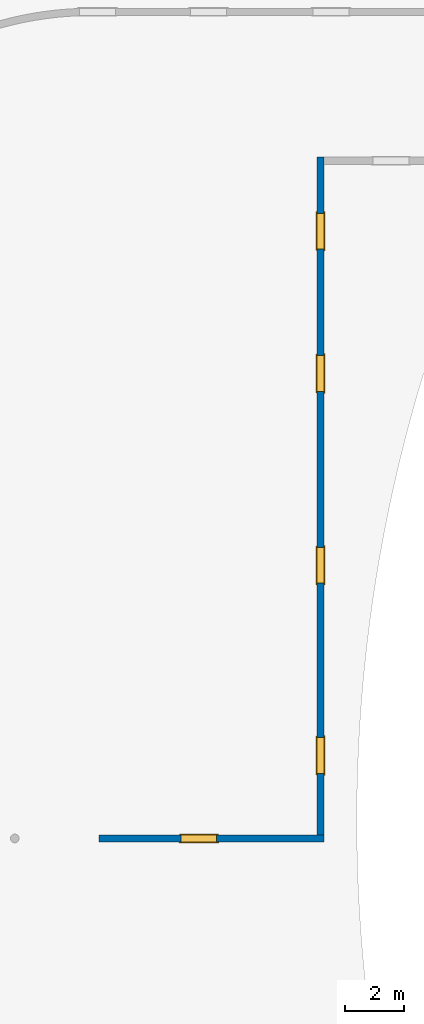
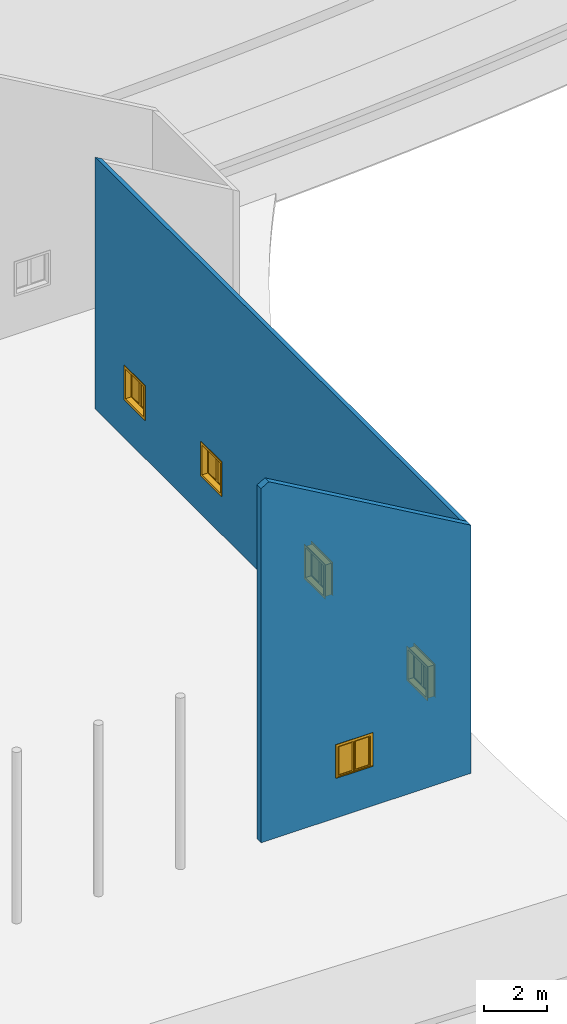
# One storey, part 8 of 39: 5 windows, 2 walls, 5 openings.
"""IFC2X3 building model written with IfcOpenShell, lengths in millimetres."""

from ifc_helpers import new_model, entity, si_unit, converted_unit, derived_unit, direction, frame, frame_2d, origin, origin_2d_with_axis, place, context, subcontext, project, spatial, polyline, rectangle, outline, extrude, clip, bounded_halfspace, source, transform, mapped, material, material_list, layer, layer_set, layer_usage, type_object, type_shapes, element, fill, save


model = new_model("IFC2X3")

# Units and contexts
model_context = context("Model", 3, precision=1e-06, world=origin(), true_north=direction((2.0, 6.12303176911189e-17, 1.0)))
context_of_model = context(None, 3, precision=1e-06, world=origin(), true_north=direction((2.0, 6.12303176911189e-17, 1.0)))
body_context = subcontext(model_context, "Body", "Model", "MODEL_VIEW")
ifc_project = project(units=[si_unit("LENGTHUNIT", "METRE", prefix="MILLI"), si_unit("AREAUNIT", "SQUARE_METRE", prefix="MILLI"), si_unit("VOLUMEUNIT", "CUBIC_METRE", prefix="MILLI"), converted_unit("PLANEANGLEUNIT", "DEGREE", entity("IfcRatioMeasure", 0.0174532925199433), si_unit("PLANEANGLEUNIT", "RADIAN"), dimensions=[0, 0, 0, 0, 0, 0, 0]), si_unit("MASSUNIT", "GRAM", prefix="KILO"), si_unit("TIMEUNIT", "SECOND"), si_unit("THERMODYNAMICTEMPERATUREUNIT", "KELVIN"), derived_unit("THERMALTRANSMITTANCEUNIT", [(si_unit("MASSUNIT", "GRAM", prefix="KILO"), 1), (si_unit("THERMODYNAMICTEMPERATUREUNIT", "KELVIN"), -1), (si_unit("TIMEUNIT", "SECOND"), -3)]), derived_unit("VOLUMETRICFLOWRATEUNIT", [(si_unit("LENGTHUNIT", "METRE"), 3), (si_unit("TIMEUNIT", "SECOND"), -1)])], contexts=[model_context, context_of_model])

# Site, building, storey
site_placement = place(None, origin())
site = spatial("IfcSite", under=ifc_project, at=site_placement, CompositionType="ELEMENT")
building_placement = place(site_placement, origin())
building = spatial("IfcBuilding", under=site, at=building_placement, CompositionType="ELEMENT")
storey_placement = place(building_placement, frame((0.0, 0.0, 4000.0)))
storey = spatial("IfcBuildingStorey", under=building, at=storey_placement, Name="Level 2", CompositionType="ELEMENT", Elevation=4000.0)

# Wall, opening, window
ifc_material_1 = material(Name="Concrete - Cast In Situ")
ifc_layer = layer(ifc_material_1, 250.0)
ifc_layer_set = layer_set([ifc_layer], Name="Basic Wall:Structure wall")
ifc_layer_usage_1 = layer_usage(ifc_layer_set, "AXIS2", "NEGATIVE", 125.0)
wall_type = type_object("IfcWallType", Name="Basic Wall:Structure wall", PredefinedType="STANDARD", material=ifc_layer_set)
wall_1_placement = place(storey_placement, frame((-325307.211895131, 224652.530060918, 362.0)))
wall_1 = element("IfcWallStandardCase", 1, at=wall_1_placement, inside=storey, type_object=wall_type, material=ifc_layer_usage_1, Name="Basic Wall:Structure wall", ObjectType="Basic Wall:Structure wall", context=body_context, shape_type="Clipping", body=[
    clip(clip(extrude(rectangle(XDim=7689.99999999995, YDim=249.999999999978, at=frame_2d((3844.99999999998, -4.06430444854777e-12), x_axis=(-1.0, 0.0))), origin(), (0.0, 0.0, 1.0), 13883.745878329), bounded_halfspace(frame((286.015685906168, -125.0, 13883.745878329), z_axis=(0.499999999999959, 0.0, 0.866025403784462), x_axis=(0.0, 1.0, 0.0)), False, frame((286.015685906168, -125.0, 13883.745878329)), polyline([(0.0, 0.0), (7403.98431409377, 0.0), (7403.98431409377, 250.0), (7153.98431409379, 250.0), (0.0, 250.0), (0.0, 0.0)]))), bounded_halfspace(frame((0.0, -125.0, 13718.6146450786), z_axis=(-0.499999999999959, 0.0, 0.866025403784462), x_axis=(0.0, -1.0, 0.0)), False, frame((0.0, -125.0, 13718.6146450786)), polyline([(0.0, 0.0), (286.01568590618, 0.0), (286.015685906179, 250.0), (0.0, 250.0), (0.0, 0.0)]))),
])
opening_1_placement = place(wall_1_placement, frame((4020.0, 125.0, 1553.0)))
opening_1 = element("IfcOpeningElement", 2, at=opening_1_placement, cuts=wall_1, Name="M_Casement Dbl with Trim:1220 x 1220mm:1220 x 1220mm:1", ObjectType="Opening", context=body_context, shape_type="SweptSolid", body=[
    extrude(rectangle(XDim=1220.0, YDim=1220.0, at=frame_2d((610.0, 610.0), x_axis=(-1.0, 0.0))), frame((0.0, 0.0, 0.0), z_axis=(0.0, -1.0, 0.0), x_axis=(0.0, 0.0, 1.0)), (0.0, 0.0, 1.0), 250.0),
])
ifc_material_2 = material(Name="Glass")
ifc_material_3 = material(Name="Sash")
ifc_material_4 = material(Name="Trim")
ifc_material_list_1 = material_list([ifc_material_2, ifc_material_3, ifc_material_4])
ifc_material_list_2 = material_list([ifc_material_2, ifc_material_3, ifc_material_4])
window_style_1 = type_object("IfcWindowStyle", Name="1220 x 1220mm", ConstructionType="NOTDEFINED", OperationType="NOTDEFINED", ParameterTakesPrecedence=False, Sizeable=False, material=ifc_material_list_2)
shared_shape_1 = source(origin(), body_context, "Body", "SweptSolid", [
    extrude(rectangle(XDim=12.7, YDim=482.999999999998, at=origin_2d_with_axis()), frame((915.0, 208.775, 63.5000000000002), z_axis=(0.0, 0.0, 1.0), x_axis=(0.0, -1.0, 0.0)), (0.0, 0.0, 1.0), 1093.0),
    extrude(outline(polyline([(-285.949999999999, -590.950000000002), (285.949999999999, -590.950000000002), (285.949999999999, 590.950000000003), (-285.949999999999, 590.950000000003), (-285.949999999999, -590.950000000002)]), holes=[polyline([(-241.499999999998, -546.500000000003), (-241.499999999998, 546.500000000002), (241.5, 546.500000000002), (241.5, -546.500000000003), (-241.499999999998, -546.500000000003)])]), frame((915.0, 186.55, 610.0), z_axis=(0.0, 1.0, 0.0), x_axis=(1.0, 0.0, 0.0)), (0.0, 0.0, 1.0), 44.45),
    extrude(rectangle(XDim=25.7, YDim=1359.89999999999, at=frame_2d((-1.68753899743024e-14, 0.0), x_axis=(1.0, 0.0))), frame((610.0, 262.85, 0.0), z_axis=(0.0, 0.0, 1.0), x_axis=(0.0, -1.0, 0.0)), (0.0, 0.0, 1.0), 19.0500000000014),
    extrude(outline(polyline([(-568.700000000007, 590.949999999995), (613.200000000007, 590.949999999995), (613.200000000007, 679.949999999994), (-657.700000000005, 679.949999999994), (-657.700000000005, -679.949999999993), (613.200000000006, -679.949999999993), (613.200000000006, -590.949999999995), (-568.700000000007, -590.949999999995), (-568.700000000007, 590.949999999995)])), frame((610.0, 250.0, 632.250000000007), z_axis=(0.0, 1.0, 0.0), x_axis=(0.0, 0.0, -1.0)), (0.0, 0.0, 1.0), 13.0),
    extrude(outline(polyline([(-667.25000000001, -667.249999999998), (667.25000000001, -667.249999999998), (667.25000000001, 667.249999999998), (-667.25000000001, 667.249999999998), (-667.25000000001, -667.249999999998)]), holes=[polyline([(-578.250000000011, -578.250000000001), (-578.250000000011, 578.249999999997), (578.24999999999, 578.249999999997), (578.24999999999, -578.250000000001), (-578.250000000011, -578.250000000001)])]), frame((610.0, -19.0, 610.0), z_axis=(0.0, 1.0, 0.0), x_axis=(0.0, 0.0, -1.0)), (0.0, 0.0, 1.0), 19.0),
    extrude(rectangle(XDim=12.7, YDim=482.999999999998, at=frame_2d((1.68753899743024e-14, 4.2632564145606e-14), x_axis=(1.0, 0.0))), frame((305.0, 208.775, 63.4999999999994), z_axis=(0.0, 0.0, 1.0), x_axis=(0.0, 1.0, 0.0)), (0.0, 0.0, 1.0), 1093.0),
    extrude(outline(polyline([(-285.949999999999, -590.950000000002), (285.949999999999, -590.950000000002), (285.949999999999, 590.950000000002), (-285.949999999999, 590.950000000002), (-285.949999999999, -590.950000000002)]), holes=[polyline([(-241.499999999999, -546.500000000003), (-241.499999999999, 546.500000000001), (241.499999999999, 546.500000000001), (241.499999999999, -546.500000000003), (-241.499999999999, -546.500000000003)])]), frame((305.0, 186.55, 610.0), z_axis=(0.0, 1.0, 0.0), x_axis=(1.0, 0.0, 0.0)), (0.0, 0.0, 1.0), 44.45),
    extrude(outline(polyline([(-610.0, -610.0), (610.0, -610.0), (610.0, 610.0), (-610.0, 610.0), (-610.0, -610.0)]), holes=[polyline([(-578.25, -578.250000000001), (-578.25, 578.25), (578.249999999997, 578.25), (578.249999999997, -578.250000000001), (-578.25, -578.250000000001)])]), frame((610.0, 0.0, 610.0), z_axis=(0.0, 1.0, 0.0), x_axis=(1.0, 0.0, 0.0)), (0.0, 0.0, 1.0), 186.55),
    extrude(outline(polyline([(-610.0, -610.0), (610.0, -610.0), (610.0, 610.0), (-610.0, 610.0), (-610.0, -610.0)]), holes=[polyline([(-590.950000000002, -590.949999999996), (-590.950000000002, 590.95), (590.950000000003, 590.95), (590.950000000003, -590.949999999996), (-590.950000000002, -590.949999999996)])]), frame((610.0, 186.55, 610.0), z_axis=(0.0, 1.0, 0.0), x_axis=(0.0, 0.0, -1.0)), (0.0, 0.0, 1.0), 63.45),
    extrude(rectangle(XDim=63.5, YDim=38.0999999999998, at=frame_2d((-8.88178419700125e-15, 0.0), x_axis=(1.0, 0.0))), frame((610.0, 218.3, 19.0499999999995), z_axis=(0.0, 0.0, 1.0), x_axis=(0.0, 1.0, 0.0)), (0.0, 0.0, 1.0), 1181.90000000001),
])
type_shapes(window_style_1, [shared_shape_1])
window_1_placement = place(opening_1_placement, frame((0.0, 0.0, 0.0), z_axis=(0.0, 0.0, 1.0), x_axis=(-1.0, 0.0, 0.0)))
window_1 = element("IfcWindow", 3, at=window_1_placement, inside=storey, type_object=window_style_1, material=ifc_material_list_1, Name="M_Casement Dbl with Trim:1220 x 1220mm", ObjectType="1220 x 1220mm", OverallHeight=1220.0, OverallWidth=1220.0, context=body_context, shape_type="MappedRepresentation", body=[
    mapped(shared_shape_1, transform((0.0, 0.0, 0.0), scale=1.0)),
])
fill(opening_1, window_1)

# Wall, openings, windows
ifc_layer_usage_2 = layer_usage(ifc_layer_set, "AXIS2", "NEGATIVE", 125.0)
wall_2_placement = place(storey_placement, frame((-317742.211895131, 224777.530060918, 362.0), z_axis=(0.0, 0.0, 1.0), x_axis=(0.0, 1.0, 0.0)))
wall_2 = element("IfcWallStandardCase", 4, at=wall_2_placement, inside=storey, type_object=wall_type, material=ifc_layer_usage_2, Name="Basic Wall:Structure wall", ObjectType="Basic Wall:Structure wall", context=body_context, shape_type="Clipping", body=[
    clip(extrude(rectangle(XDim=23161.8749347836, YDim=249.999999999978, at=frame_2d((11580.9374673918, -3.76587649952853e-13), x_axis=(-1.0, 0.0))), origin(), (0.0, 0.0, 1.0), 9753.39110880907), bounded_halfspace(frame((0.0, -125.0, 9609.0535415117), z_axis=(0.0, -0.499999999999959, 0.866025403784462), x_axis=(1.0, 0.0, 0.0)), False, frame((0.0, -125.0, 9609.0535415117)), polyline([(0.0, 0.0), (22911.8749347836, 0.0), (23161.8749347836, 0.0), (23161.8749347836, 250.0), (0.0, 250.0), (0.0, 0.0)]))),
])
opening_2_placement = place(wall_2_placement, frame((3320.0, 125.0, 1553.0)))
opening_2 = element("IfcOpeningElement", 5, at=opening_2_placement, cuts=wall_2, Name="M_Casement Dbl with Trim:1220 x 1220mm:1220 x 1220mm:1", ObjectType="Opening", context=body_context, shape_type="SweptSolid", body=[
    extrude(rectangle(XDim=1220.0, YDim=1220.0, at=frame_2d((610.0, 610.0), x_axis=(-1.0, 0.0))), frame((0.0, 0.0, 0.0), z_axis=(0.0, -1.0, 0.0), x_axis=(0.0, 0.0, 1.0)), (0.0, 0.0, 1.0), 250.0),
])
opening_3_placement = place(wall_2_placement, frame((9820.0, 125.0, 1553.0)))
opening_3 = element("IfcOpeningElement", 6, at=opening_3_placement, cuts=wall_2, Name="M_Casement Dbl with Trim:1220 x 1220mm:1220 x 1220mm:1", ObjectType="Opening", context=body_context, shape_type="SweptSolid", body=[
    extrude(rectangle(XDim=1220.0, YDim=1220.0, at=frame_2d((610.0, 610.0), x_axis=(-1.0, 0.0))), frame((0.0, 0.0, 0.0), z_axis=(0.0, -1.0, 0.0), x_axis=(0.0, 0.0, 1.0)), (0.0, 0.0, 1.0), 250.0),
])
opening_4_placement = place(wall_2_placement, frame((16379.9, 125.0, 1553.0)))
opening_4 = element("IfcOpeningElement", 7, at=opening_4_placement, cuts=wall_2, Name="M_Casement Dbl with Trim:1220 x 1220mm:1220 x 1220mm:1", ObjectType="Opening", context=body_context, shape_type="SweptSolid", body=[
    extrude(rectangle(XDim=1220.0, YDim=1220.0, at=frame_2d((610.0, 610.0), x_axis=(-1.0, 0.0))), frame((0.0, 0.0, 0.0), z_axis=(0.0, -1.0, 0.0), x_axis=(0.0, 0.0, 1.0)), (0.0, 0.0, 1.0), 250.0),
])
opening_5_placement = place(wall_2_placement, frame((21241.9249347836, 125.0, 1553.0)))
opening_5 = element("IfcOpeningElement", 8, at=opening_5_placement, cuts=wall_2, Name="M_Casement Dbl with Trim:1220 x 1220mm:1220 x 1220mm:1", ObjectType="Opening", context=body_context, shape_type="SweptSolid", body=[
    extrude(rectangle(XDim=1220.0, YDim=1220.0, at=frame_2d((610.0, 610.0), x_axis=(-1.0, 0.0))), frame((0.0, 0.0, 0.0), z_axis=(0.0, -1.0, 0.0), x_axis=(0.0, 0.0, 1.0)), (0.0, 0.0, 1.0), 250.0),
])
ifc_material_list_3 = material_list([ifc_material_2, ifc_material_3, ifc_material_4])
ifc_material_list_4 = material_list([ifc_material_2, ifc_material_3, ifc_material_4])
window_style_2 = type_object("IfcWindowStyle", Name="1220 x 1220mm", ConstructionType="NOTDEFINED", OperationType="NOTDEFINED", ParameterTakesPrecedence=False, Sizeable=False, material=ifc_material_list_4)
shared_shape_2 = source(origin(), body_context, "Body", "SweptSolid", [
    extrude(rectangle(XDim=482.999999999998, YDim=12.7, at=frame_2d((0.0, -1.68753899743024e-14), x_axis=(1.0, 0.0))), frame((305.0, 246.875, 63.5000000000002), z_axis=(0.0, 0.0, 1.0), x_axis=(-1.0, 0.0, 0.0)), (0.0, 0.0, 1.0), 1093.0),
    extrude(outline(polyline([(-285.949999999999, -590.950000000002), (285.949999999999, -590.950000000002), (285.949999999999, 590.950000000003), (-285.949999999999, 590.950000000003), (-285.949999999999, -590.950000000002)]), holes=[polyline([(-241.499999999998, -546.500000000003), (-241.499999999998, 546.500000000002), (241.5, 546.500000000002), (241.5, -546.500000000003), (-241.499999999998, -546.500000000003)])]), frame((305.0, 269.1, 610.0), z_axis=(0.0, -1.0, 0.0), x_axis=(-1.0, 0.0, 0.0)), (0.0, 0.0, 1.0), 44.45),
    extrude(rectangle(XDim=1359.89999999999, YDim=25.7, at=frame_2d((0.0, -1.68753899743024e-14), x_axis=(1.0, 0.0))), frame((610.0, 300.95, 0.0), z_axis=(0.0, 0.0, 1.0), x_axis=(-1.0, 0.0, 0.0)), (0.0, 0.0, 1.0), 19.0500000000014),
    extrude(outline(polyline([(-568.700000000007, 590.949999999995), (613.200000000007, 590.949999999995), (613.200000000007, 679.949999999994), (-657.700000000005, 679.949999999994), (-657.700000000005, -679.949999999993), (613.200000000006, -679.949999999993), (613.200000000006, -590.949999999995), (-568.700000000007, -590.949999999995), (-568.700000000007, 590.949999999995)])), frame((610.0, 301.1, 632.250000000007), z_axis=(0.0, -1.0, 0.0), x_axis=(0.0, 0.0, -1.0)), (0.0, 0.0, 1.0), 13.0),
    extrude(outline(polyline([(-667.25000000001, -667.249999999998), (667.25000000001, -667.249999999998), (667.25000000001, 667.249999999998), (-667.25000000001, 667.249999999998), (-667.25000000001, -667.249999999998)]), holes=[polyline([(-578.250000000011, -578.250000000001), (-578.250000000011, 578.249999999997), (578.24999999999, 578.249999999997), (578.24999999999, -578.250000000001), (-578.250000000011, -578.250000000001)])]), frame((610.0, 38.1, 610.0), z_axis=(0.0, -1.0, 0.0), x_axis=(0.0, 0.0, -1.0)), (0.0, 0.0, 1.0), 19.0),
    extrude(rectangle(XDim=482.999999999998, YDim=12.7, at=frame_2d((4.2632564145606e-14, 0.0), x_axis=(1.0, 0.0))), frame((915.0, 246.875, 63.4999999999994)), (0.0, 0.0, 1.0), 1093.0),
    extrude(outline(polyline([(-285.949999999999, -590.950000000002), (285.949999999999, -590.950000000002), (285.949999999999, 590.950000000002), (-285.949999999999, 590.950000000002), (-285.949999999999, -590.950000000002)]), holes=[polyline([(-241.499999999999, -546.500000000003), (-241.499999999999, 546.500000000001), (241.499999999999, 546.500000000001), (241.499999999999, -546.500000000003), (-241.499999999999, -546.500000000003)])]), frame((915.0, 269.1, 610.0), z_axis=(0.0, -1.0, 0.0), x_axis=(-1.0, 0.0, 0.0)), (0.0, 0.0, 1.0), 44.45),
    extrude(outline(polyline([(-610.0, -610.0), (610.0, -610.0), (610.0, 610.0), (-610.0, 610.0), (-610.0, -610.0)]), holes=[polyline([(-578.25, -578.250000000001), (-578.25, 578.25), (578.249999999997, 578.25), (578.249999999997, -578.250000000001), (-578.25, -578.250000000001)])]), frame((610.0, 224.65, 610.0), z_axis=(0.0, -1.0, 0.0), x_axis=(-1.0, 0.0, 0.0)), (0.0, 0.0, 1.0), 186.55),
    extrude(outline(polyline([(-610.0, -610.0), (610.0, -610.0), (610.0, 610.0), (-610.0, 610.0), (-610.0, -610.0)]), holes=[polyline([(-590.950000000002, -590.949999999996), (-590.950000000002, 590.95), (590.950000000003, 590.95), (590.950000000003, -590.949999999996), (-590.950000000002, -590.949999999996)])]), frame((610.0, 288.1, 610.0), z_axis=(0.0, -1.0, 0.0), x_axis=(0.0, 0.0, -1.0)), (0.0, 0.0, 1.0), 63.45),
    extrude(rectangle(XDim=38.0999999999998, YDim=63.5, at=frame_2d((0.0, -8.88178419700125e-15), x_axis=(1.0, 0.0))), frame((610.0, 256.4, 19.0499999999995)), (0.0, 0.0, 1.0), 1181.90000000001),
])
type_shapes(window_style_2, [shared_shape_2])
window_2_placement = place(opening_4_placement, frame((0.0, 38.0999999999185, 0.0), z_axis=(0.0, 0.0, 1.0), x_axis=(-1.0, 0.0, 0.0)))
window_2 = element("IfcWindow", 9, at=window_2_placement, inside=storey, type_object=window_style_2, material=ifc_material_list_3, Name="M_Casement Dbl with Trim:1220 x 1220mm", ObjectType="1220 x 1220mm", OverallHeight=1220.0, OverallWidth=1220.0, context=body_context, shape_type="MappedRepresentation", body=[
    mapped(shared_shape_2, transform((0.0, 0.0, 0.0), scale=1.0)),
])
fill(opening_4, window_2)
ifc_material_list_5 = material_list([ifc_material_2, ifc_material_3, ifc_material_4])
window_3_placement = place(opening_2_placement, frame((0.0, 0.0, 0.0), z_axis=(0.0, 0.0, 1.0), x_axis=(-1.0, 0.0, 0.0)))
window_3 = element("IfcWindow", 10, at=window_3_placement, inside=storey, type_object=window_style_1, material=ifc_material_list_5, Name="M_Casement Dbl with Trim:1220 x 1220mm", ObjectType="1220 x 1220mm", OverallHeight=1220.0, OverallWidth=1220.0, context=body_context, shape_type="MappedRepresentation", body=[
    mapped(shared_shape_1, transform((0.0, 0.0, 0.0), scale=1.0)),
])
fill(opening_2, window_3)
ifc_material_list_6 = material_list([ifc_material_2, ifc_material_3, ifc_material_4])
window_4_placement = place(opening_3_placement, frame((0.0, 0.0, 0.0), z_axis=(0.0, 0.0, 1.0), x_axis=(-1.0, 0.0, 0.0)))
window_4 = element("IfcWindow", 11, at=window_4_placement, inside=storey, type_object=window_style_1, material=ifc_material_list_6, Name="M_Casement Dbl with Trim:1220 x 1220mm", ObjectType="1220 x 1220mm", OverallHeight=1220.0, OverallWidth=1220.0, context=body_context, shape_type="MappedRepresentation", body=[
    mapped(shared_shape_1, transform((0.0, 0.0, 0.0), scale=1.0)),
])
fill(opening_3, window_4)
ifc_material_list_7 = material_list([ifc_material_2, ifc_material_3, ifc_material_4])
window_5_placement = place(opening_5_placement, frame((0.0, 0.0, 0.0), z_axis=(0.0, 0.0, 1.0), x_axis=(-1.0, 0.0, 0.0)))
window_5 = element("IfcWindow", 12, at=window_5_placement, inside=storey, type_object=window_style_1, material=ifc_material_list_7, Name="M_Casement Dbl with Trim:1220 x 1220mm", ObjectType="1220 x 1220mm", OverallHeight=1220.0, OverallWidth=1220.0, context=body_context, shape_type="MappedRepresentation", body=[
    mapped(shared_shape_1, transform((0.0, 0.0, 0.0), scale=1.0)),
])
fill(opening_5, window_5)

save(model, "model.ifc")
